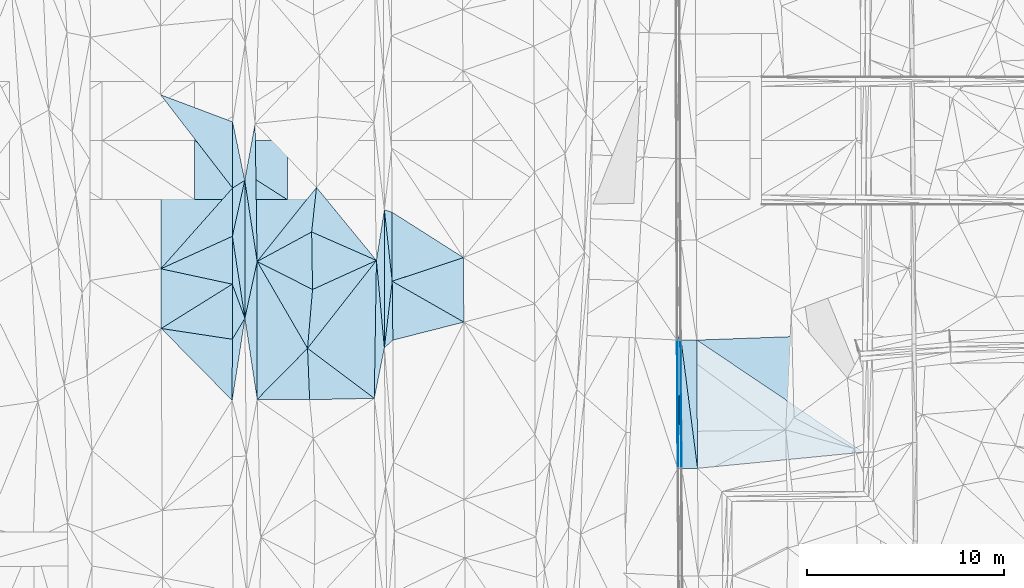
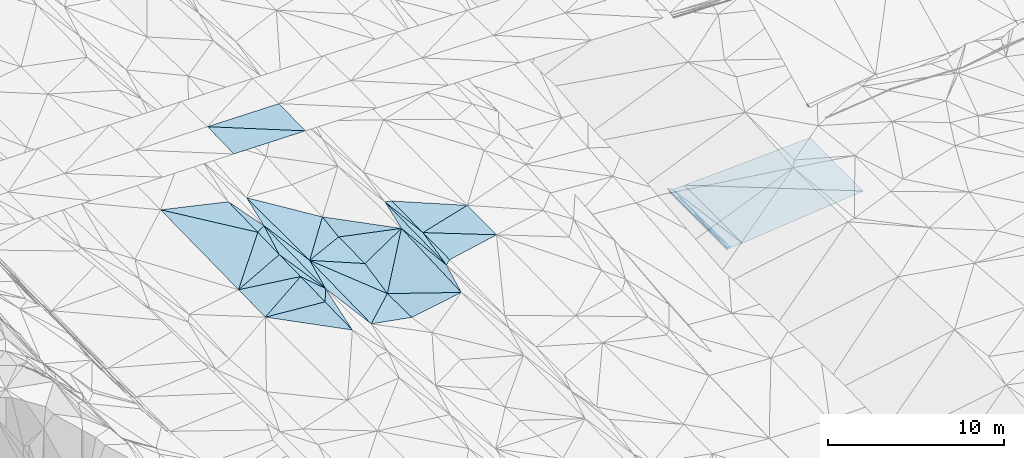
# One storey, part 94 of 275: 46 plates.
"""IFC2X3 building model written with IfcOpenShell, lengths in millimetres."""

from ifc_helpers import new_model, si_unit, frame, origin_with_axes, place, context, subcontext, project, spatial, polyline, outline, extrude, material, type_object, element, save


model = new_model("IFC2X3")

# Units and contexts
model_context = context("Model", 3, precision=1e-05, world=origin_with_axes())
body_context = subcontext(model_context, "Body", "Model", "MODEL_VIEW")
ifc_project = project(units=[si_unit("LENGTHUNIT", "METRE", prefix="MILLI"), si_unit("AREAUNIT", "SQUARE_METRE"), si_unit("VOLUMEUNIT", "CUBIC_METRE"), si_unit("MASSUNIT", "GRAM", prefix="KILO"), si_unit("TIMEUNIT", "SECOND"), si_unit("PLANEANGLEUNIT", "RADIAN"), si_unit("SOLIDANGLEUNIT", "STERADIAN"), si_unit("THERMODYNAMICTEMPERATUREUNIT", "DEGREE_CELSIUS"), si_unit("LUMINOUSINTENSITYUNIT", "LUMEN")], contexts=[model_context])

# Site, building, storey
site_placement = place(None, origin_with_axes())
site = spatial("IfcSite", under=ifc_project, at=site_placement, CompositionType="ELEMENT")
building_placement = place(site_placement, origin_with_axes())
building = spatial("IfcBuilding", under=site, at=building_placement, Name="Undefined", CompositionType="ELEMENT")
storey_placement = place(building_placement, origin_with_axes())
storey = spatial("IfcBuildingStorey", under=building, at=storey_placement, Name="Undefined", CompositionType="ELEMENT", Elevation=0.0)

# Plates
ifc_material = material()
plate_type_1 = type_object("IfcPlateType", PredefinedType="NOTDEFINED")
plate_1_placement = place(storey_placement, frame((-76301.4803001761, 52741.8011921955, 41943.5069335695), z_axis=(-0.164503150985171, 0.0230681311976254, -0.986106776489747), x_axis=(-0.698632672753425, -0.708461515449737, 0.0999733448878618)))
element("IfcPlate", 1, at=plate_1_placement, inside=storey, type_object=plate_type_1, material=ifc_material, Name="00", context=body_context, shape_type="SweptSolid", body=[
    extrude(outline(polyline([(0.0, 0.0), (3660.97583007813, 1.54977897182107e-08), (-1283.78015136719, 4962.62841796875), (0.0, 0.0)])), frame((-8.85201319254618e-08, 2.18876761149539e-07, -0.5000001331573), z_axis=(0.0, 0.0, 1.0), x_axis=(1.0, 0.0, 0.0)), (0.0, 0.0, 1.0), 1.0),
])
plate_type_2 = type_object("IfcPlateType", PredefinedType="NOTDEFINED")
plate_2_placement = place(storey_placement, frame((-57542.9530293988, 53163.1576306865, 42166.8175924955), z_axis=(0.970027688834768, 0.00927892419382977, -0.242817183205153), x_axis=(0.104742525961626, 0.885703765879376, 0.452280711906079)))
element("IfcPlate", 2, at=plate_2_placement, inside=storey, type_object=plate_type_2, material=ifc_material, Name="00_PR", context=body_context, shape_type="SweptSolid", body=[
    extrude(outline(polyline([(0.0, 0.0), (273.964813232422, 8.65838956087828e-10), (-5761.70263671875, 3058.12841796875), (0.0, 0.0)])), frame((-8.85201319254618e-08, 2.18876761149539e-07, -0.5000001331573), z_axis=(0.0, 0.0, 1.0), x_axis=(1.0, 0.0, 0.0)), (0.0, 0.0, 1.0), 1.0),
])
plate_3_placement = place(storey_placement, frame((-57475.9206408906, 46640.5409717461, 42185.3517366158), z_axis=(0.970098716719788, 0.00928046165619279, -0.242533199480129), x_axis=(-0.242518705977358, -0.00267351303617726, -0.970143045936584)))
element("IfcPlate", 3, at=plate_3_placement, inside=storey, type_object=plate_type_2, material=ifc_material, Name="00_PR", context=body_context, shape_type="SweptSolid", body=[
    extrude(outline(polyline([(0.0, 0.0), (123.693099975586, 3.20142135024071e-10), (16.7989311218262, 6522.9658203125), (0.0, 0.0)])), frame((-8.85201319254618e-08, 2.18876761149539e-07, -0.5000001331573), z_axis=(0.0, 0.0, 1.0), x_axis=(1.0, 0.0, 0.0)), (0.0, 0.0, 1.0), 1.0),
])
plate_type_3 = type_object("IfcPlateType", PredefinedType="NOTDEFINED")
plate_4_placement = place(storey_placement, frame((-57363.4039032815, 53156.8138091061, 42286.1950642399), z_axis=(-0.0018315013619723, 0.0155635878299148, -0.999877202628714), x_axis=(-0.0173369269780069, -0.999729095698535, -0.0155295259666189)))
element("IfcPlate", 4, at=plate_4_placement, inside=storey, type_object=plate_type_3, material=ifc_material, Name="00_PR", context=body_context, shape_type="SweptSolid", body=[
    extrude(outline(polyline([(0.0, 0.0), (6518.03564453125, -6.01721694692969e-09), (-246.37190246582, 155.63427734375), (0.0, 0.0)])), frame((-8.85201319254618e-08, 2.18876761149539e-07, -0.5000001331573), z_axis=(0.0, 0.0, 1.0), x_axis=(1.0, 0.0, 0.0)), (0.0, 0.0, 1.0), 1.0),
])
plate_5_placement = place(storey_placement, frame((-57476.4057313852, 46640.5440982335, 42184.9730634497), z_axis=(-8.17458339498182e-05, 0.0155332775498267, -0.99987934802464), x_axis=(0.0173369269796735, 0.999729095698539, 0.0155295259645527)))
element("IfcPlate", 5, at=plate_5_placement, inside=storey, type_object=plate_type_3, material=ifc_material, Name="00_PR", context=body_context, shape_type="SweptSolid", body=[
    extrude(outline(polyline([(0.0, 0.0), (6518.03564453125, -6.01721694692969e-09), (3.38969159126282, 149.96240234375), (0.0, 0.0)])), frame((-8.85201319254618e-08, 2.18876761149539e-07, -0.5000001331573), z_axis=(0.0, 0.0, 1.0), x_axis=(1.0, 0.0, 0.0)), (0.0, 0.0, 1.0), 1.0),
])
plate_type_4 = type_object("IfcPlateType", PredefinedType="NOTDEFINED")
plate_6_placement = place(storey_placement, frame((-57326.3971217367, 46641.3335447371, 42184.9731635191), z_axis=(0.0198966191931346, 0.0156436936725844, -0.999679648383902), x_axis=(-0.00567731102486509, 0.999863228802967, 0.0155335709749377)))
element("IfcPlate", 6, at=plate_6_placement, inside=storey, type_object=plate_type_4, material=ifc_material, Name="00_PR", context=body_context, shape_type="SweptSolid", body=[
    extrude(outline(polyline([(0.0, 0.0), (6516.37158203125, -1.07465893961489e-08), (0.0258967056870461, 30.0057029724121), (0.0, 0.0)])), frame((-8.85201319254618e-08, 2.18876761149539e-07, -0.5000001331573), z_axis=(0.0, 0.0, 1.0), x_axis=(1.0, 0.0, 0.0)), (0.0, 0.0, 1.0), 1.0),
])
plate_type_5 = type_object("IfcPlateType", PredefinedType="NOTDEFINED")
plate_7_placement = place(storey_placement, frame((-80125.2773440226, 55999.8433321233, 42489.500651023), z_axis=(0.0468589164748065, 0.0214401011975967, -0.998671399413963), x_axis=(0.348086938581272, -0.937454582870277, -0.00379318397038464)))
element("IfcPlate", 7, at=plate_7_placement, inside=storey, type_object=plate_type_5, material=ifc_material, Name="00", context=body_context, shape_type="SweptSolid", body=[
    extrude(outline(polyline([(0.0, 0.0), (1845.41516113281, -7.04312697052956e-09), (2624.07080078125, 973.833801269531), (0.0, 0.0)])), frame((-8.85201319254618e-08, 2.18876761149539e-07, -0.5000001331573), z_axis=(0.0, 0.0, 1.0), x_axis=(1.0, 0.0, 0.0)), (0.0, 0.0, 1.0), 1.0),
])
plate_type_6 = type_object("IfcPlateType", PredefinedType="NOTDEFINED")
plate_8_placement = place(storey_placement, frame((-48114.4722164906, 53466.44615414, 42475.5971621277), z_axis=(0.0199483858751365, 0.0157255967436064, -0.9996773316966), x_axis=(0.00717889702380228, -0.99985277310037, -0.0155851070262992)))
element("IfcPlate", 8, at=plate_8_placement, inside=storey, type_object=plate_type_6, material=ifc_material, Name="00_PR", context=body_context, shape_type="SweptSolid", body=[
    extrude(outline(polyline([(0.0, 0.0), (6000.72900390625, 1.8364517018199e-08), (247.582382202148, 8422.6015625), (0.0, 0.0)])), frame((-8.85201319254618e-08, 2.18876761149539e-07, -0.5000001331573), z_axis=(0.0, 0.0, 1.0), x_axis=(1.0, 0.0, 0.0)), (0.0, 0.0, 1.0), 1.0),
])
plate_type_7 = type_object("IfcPlateType", PredefinedType="NOTDEFINED")
plate_9_placement = place(storey_placement, frame((-56533.403672107, 53161.0745676189, 42302.7951620427), z_axis=(0.0199135154887718, 0.0156458617125591, -0.999679278024782), x_axis=(0.00567739699385721, -0.999863196060369, -0.0155356469874529)))
element("IfcPlate", 9, at=plate_9_placement, inside=storey, type_object=plate_type_7, material=ifc_material, Name="00_PR", context=body_context, shape_type="SweptSolid", body=[
    extrude(outline(polyline([(0.0, 0.0), (6515.46728515625, 2.04963725991547e-08), (-0.186443611979485, 800.160095214844), (0.0, 0.0)])), frame((-8.85201319254618e-08, 2.18876761149539e-07, -0.5000001331573), z_axis=(0.0, 0.0, 1.0), x_axis=(1.0, 0.0, 0.0)), (0.0, 0.0, 1.0), 1.0),
])
plate_10_placement = place(storey_placement, frame((-57296.3979868515, 46641.5204637476, 42185.573161535), z_axis=(0.0198966191931346, 0.0156436936725844, -0.999679648383902), x_axis=(-0.00567731102486509, 0.999863228802967, 0.0155335709749377)))
element("IfcPlate", 10, at=plate_10_placement, inside=storey, type_object=plate_type_7, material=ifc_material, Name="00_PR", context=body_context, shape_type="SweptSolid", body=[
    extrude(outline(polyline([(0.0, 0.0), (6516.337890625, -1.64873199537396e-08), (0.684065341949463, 800.160400390625), (0.0, 0.0)])), frame((-8.85201319254618e-08, 2.18876761149539e-07, -0.5000001331573), z_axis=(0.0, 0.0, 1.0), x_axis=(1.0, 0.0, 0.0)), (0.0, 0.0, 1.0), 1.0),
])
plate_type_8 = type_object("IfcPlateType", PredefinedType="NOTDEFINED")
plate_11_placement = place(storey_placement, frame((-56496.4127879231, 46646.4983941484, 42201.5731610095), z_axis=(0.0198946814764051, 0.0156457606167164, -0.999679654601251), x_axis=(-0.00567739699168185, 0.999863196060446, 0.0155356469832898)))
element("IfcPlate", 11, at=plate_11_placement, inside=storey, type_object=plate_type_8, material=ifc_material, Name="00_PR", context=body_context, shape_type="SweptSolid", body=[
    extrude(outline(polyline([(0.0, 0.0), (6515.46728515625, 2.04963725991547e-08), (774.961853027344, 8431.22265625), (0.0, 0.0)])), frame((-8.85201319254618e-08, 2.18876761149539e-07, -0.5000001331573), z_axis=(0.0, 0.0, 1.0), x_axis=(1.0, 0.0, 0.0)), (0.0, 0.0, 1.0), 1.0),
])
plate_type_9 = type_object("IfcPlateType", PredefinedType="NOTDEFINED")
plate_12_placement = place(storey_placement, frame((-72001.2179249865, 56147.3635564069, 42609.5001382948), z_axis=(-0.0142082783030577, 0.0199258904361821, -0.999700497007973), x_axis=(-0.109600104546313, 0.993746123494189, 0.021364904018242)))
element("IfcPlate", 12, at=plate_12_placement, inside=storey, type_object=plate_type_9, material=ifc_material, Name="00", context=body_context, shape_type="SweptSolid", body=[
    extrude(outline(polyline([(0.0, 0.0), (3650.84716796875, 1.33877620100975e-08), (3486.49755859375, 376.077423095703), (0.0, 0.0)])), frame((-8.85201319254618e-08, 2.18876761149539e-07, -0.5000001331573), z_axis=(0.0, 0.0, 1.0), x_axis=(1.0, 0.0, 0.0)), (0.0, 0.0, 1.0), 1.0),
])
plate_type_10 = type_object("IfcPlateType", PredefinedType="NOTDEFINED")
plate_13_placement = place(storey_placement, frame((-72399.5642037874, 52769.8800407918, 42538.5001024984), z_axis=(-0.00209296940102115, 0.0212636173443059, -0.999771712970777), x_axis=(-0.000254156600181072, 0.999773859136731, 0.0212641950534282)))
element("IfcPlate", 13, at=plate_13_placement, inside=storey, type_object=plate_type_10, material=ifc_material, Name="00", context=body_context, shape_type="SweptSolid", body=[
    extrude(outline(polyline([(0.0, 0.0), (7007.083984375, 9.05129127204418e-09), (3378.12890625, 399.211791992188), (0.0, 0.0)])), frame((-8.85201319254618e-08, 2.18876761149539e-07, -0.5000001331573), z_axis=(0.0, 0.0, 1.0), x_axis=(1.0, 0.0, 0.0)), (0.0, 0.0, 1.0), 1.0),
])
plate_type_11 = type_object("IfcPlateType", PredefinedType="NOTDEFINED")
plate_14_placement = place(storey_placement, frame((-80117.4673250895, 58430.5698216185, 42539.5003000876), z_axis=(0.0302887753520318, 0.0183102708429095, -0.999373465762091), x_axis=(0.215693778475776, 0.976155600391087, 0.0244220750952754)))
element("IfcPlate", 14, at=plate_14_placement, inside=storey, type_object=plate_type_11, material=ifc_material, Name="00", context=body_context, shape_type="SweptSolid", body=[
    extrude(outline(polyline([(0.0, 0.0), (2907.20581054688, 2.91038304567337e-11), (-3926.03540039063, 1517.80883789063), (0.0, 0.0)])), frame((-8.85201319254618e-08, 2.18876761149539e-07, -0.5000001331573), z_axis=(0.0, 0.0, 1.0), x_axis=(1.0, 0.0, 0.0)), (0.0, 0.0, 1.0), 1.0),
])
plate_type_12 = type_object("IfcPlateType", PredefinedType="NOTDEFINED")
for number, where, z_axis, x_axis, name in (
    (15, (-77330.6102856705, 60291.3344338534, 49029.1251709202), (-0.00857472301504208, 0.024991763543276, -0.999650881998417), (-0.999963199497799, 5.72359829353127e-05, 0.00857883291408346), "00_PR"),
    (16, (-82030.4385371025, 63291.6034738542, 49144.4471702601), (-0.00857472301504208, 0.024991763543276, -0.999650881998417), (0.999963199497715, -5.72359692649372e-05, -0.00857883292399956), "00_PR"),
):
    element("IfcPlate", number, at=place(storey_placement, frame(where, z_axis=z_axis, x_axis=x_axis)), inside=storey, type_object=plate_type_12, material=ifc_material, Name=name, context=body_context, shape_type="SweptSolid", body=[
        extrude(outline(polyline([(0.0, 0.0), (4700.17333984375, 2.53130565397441e-08), (4700.81640625, 3000.93725585938), (0.0, 0.0)])), frame((-8.85201319254618e-08, 2.18876761149539e-07, -0.5000001331573), z_axis=(0.0, 0.0, 1.0), x_axis=(1.0, 0.0, 0.0)), (0.0, 0.0, 1.0), 1.0),
    ])
plate_type_13 = type_object("IfcPlateType", PredefinedType="NOTDEFINED")
plate_15_placement = place(storey_placement, frame((-76301.4848263404, 52741.8057757175, 41943.5078425189), z_axis=(-0.173566145837038, 0.0322612454600606, -0.984293657939866), x_axis=(0.0399766785479113, -0.998408712848107, -0.0397731980266146)))
element("IfcPlate", 17, at=plate_15_placement, inside=storey, type_object=plate_type_13, material=ifc_material, Name="00", context=body_context, shape_type="SweptSolid", body=[
    extrude(outline(polyline([(0.0, 0.0), (2614.826171875, 3.52156348526478e-09), (2472.72875976563, 2699.69555664063), (0.0, 0.0)])), frame((-8.85201319254618e-08, 2.18876761149539e-07, -0.5000001331573), z_axis=(0.0, 0.0, 1.0), x_axis=(1.0, 0.0, 0.0)), (0.0, 0.0, 1.0), 1.0),
])
plate_type_14 = type_object("IfcPlateType", PredefinedType="NOTDEFINED")
plate_16_placement = place(storey_placement, frame((-78860.0964348655, 57151.8084225773, 42473.5024648238), z_axis=(-0.0977172482654074, 0.0181516132345168, -0.995048671336443), x_axis=(-0.151280629542686, 0.987943919920771, 0.0328782940060852)))
element("IfcPlate", 18, at=plate_16_placement, inside=storey, type_object=plate_type_14, material=ifc_material, Name="00", context=body_context, shape_type="SweptSolid", body=[
    extrude(outline(polyline([(0.0, 0.0), (4166.8828125, -1.18016032502055e-08), (6938.66748046875, 960.960571289063), (0.0, 0.0)])), frame((-8.85201319254618e-08, 2.18876761149539e-07, -0.5000001331573), z_axis=(0.0, 0.0, 1.0), x_axis=(1.0, 0.0, 0.0)), (0.0, 0.0, 1.0), 1.0),
])
plate_type_15 = type_object("IfcPlateType", PredefinedType="NOTDEFINED")
plate_17_placement = place(storey_placement, frame((-79490.4147656237, 61268.4578826335, 42610.5001299574), z_axis=(0.00296313343199887, 0.0238163730749042, -0.999711958622993), x_axis=(-0.848854461119518, -0.528410786682991, -0.0151044481711405)))
element("IfcPlate", 19, at=plate_17_placement, inside=storey, type_object=plate_type_15, material=ifc_material, Name="00", context=body_context, shape_type="SweptSolid", body=[
    extrude(outline(polyline([(0.0, 0.0), (728.262329101563, -4.71482053399086e-09), (-1049.36645507813, 2849.7255859375), (0.0, 0.0)])), frame((-8.85201319254618e-08, 2.18876761149539e-07, -0.5000001331573), z_axis=(0.0, 0.0, 1.0), x_axis=(1.0, 0.0, 0.0)), (0.0, 0.0, 1.0), 1.0),
])
plate_type_16 = type_object("IfcPlateType", PredefinedType="NOTDEFINED")
plate_18_placement = place(storey_placement, frame((-72399.4525242251, 52769.879803559, 42538.5124933599), z_axis=(0.221259027257067, 0.0207933858666983, -0.974993373291047), x_axis=(-0.0906220355690174, 0.995885130303632, 0.000673728020362977)))
element("IfcPlate", 20, at=plate_18_placement, inside=storey, type_object=plate_type_16, material=ifc_material, Name="00", context=body_context, shape_type="SweptSolid", body=[
    extrude(outline(polyline([(0.0, 0.0), (4452.8359375, 1.33150024339557e-08), (6976.9345703125, 649.316284179688), (0.0, 0.0)])), frame((-8.85201319254618e-08, 2.18876761149539e-07, -0.5000001331573), z_axis=(0.0, 0.0, 1.0), x_axis=(1.0, 0.0, 0.0)), (0.0, 0.0, 1.0), 1.0),
])
plate_type_17 = type_object("IfcPlateType", PredefinedType="NOTDEFINED")
plate_19_placement = place(storey_placement, frame((-72803.0471153788, 57204.364844627, 42541.5019862587), z_axis=(0.0821439293381421, -0.0349046704456952, -0.996009055608415), x_axis=(-0.911780879208614, 0.400862674522966, -0.0892454171588704)))
element("IfcPlate", 21, at=plate_19_placement, inside=storey, type_object=plate_type_17, material=ifc_material, Name="00", context=body_context, shape_type="SweptSolid", body=[
    extrude(outline(polyline([(0.0, 0.0), (3608.0283203125, -5.44969225302339e-09), (4295.9521484375, 2170.42431640625), (0.0, 0.0)])), frame((-8.85201319254618e-08, 2.18876761149539e-07, -0.5000001331573), z_axis=(0.0, 0.0, 1.0), x_axis=(1.0, 0.0, 0.0)), (0.0, 0.0, 1.0), 1.0),
])
plate_type_18 = type_object("IfcPlateType", PredefinedType="NOTDEFINED")
plate_20_placement = place(storey_placement, frame((-79482.9132750018, 54269.8509620968, 42482.5006235295), z_axis=(0.0451926836642338, 0.0224421925346116, -0.998726173351567), x_axis=(-0.152564066432652, -0.987865019260411, -0.0291017070832675)))
element("IfcPlate", 22, at=plate_20_placement, inside=storey, type_object=plate_type_18, material=ifc_material, Name="00", context=body_context, shape_type="SweptSolid", body=[
    extrude(outline(polyline([(0.0, 0.0), (4226.55615234375, 6.43194653093815e-09), (1154.64379882813, 470.589660644531), (0.0, 0.0)])), frame((-8.85201319254618e-08, 2.18876761149539e-07, -0.5000001331573), z_axis=(0.0, 0.0, 1.0), x_axis=(1.0, 0.0, 0.0)), (0.0, 0.0, 1.0), 1.0),
])
plate_type_19 = type_object("IfcPlateType", PredefinedType="NOTDEFINED")
plate_21_placement = place(storey_placement, frame((-79490.4149626069, 61268.4581842369, 42610.5001380788), z_axis=(0.00257311389830372, 0.0244425101377743, -0.999697925767094), x_axis=(-0.215693778482994, -0.97615560038944, -0.0244220750973573)))
element("IfcPlate", 23, at=plate_21_placement, inside=storey, type_object=plate_type_19, material=ifc_material, Name="00", context=body_context, shape_type="SweptSolid", body=[
    extrude(outline(polyline([(0.0, 0.0), (2907.20581054688, 2.91038304567337e-11), (509.253936767578, 520.601989746094), (0.0, 0.0)])), frame((-8.85201319254618e-08, 2.18876761149539e-07, -0.5000001331573), z_axis=(0.0, 0.0, 1.0), x_axis=(1.0, 0.0, 0.0)), (0.0, 0.0, 1.0), 1.0),
])
plate_type_20 = type_object("IfcPlateType", PredefinedType="NOTDEFINED")
plate_22_placement = place(storey_placement, frame((-83733.1710688452, 53748.7930117212, 42299.5004985629), z_axis=(0.0393835493199268, 0.02245533538534, -0.998971818399146), x_axis=(0.988074759596303, -0.149806101453469, 0.0355865341951255)))
element("IfcPlate", 24, at=plate_22_placement, inside=storey, type_object=plate_type_20, material=ifc_material, Name="00", context=body_context, shape_type="SweptSolid", body=[
    extrude(outline(polyline([(0.0, 0.0), (3653.06713867188, 5.86442183703184e-09), (4111.99658203125, 3073.67602539063), (0.0, 0.0)])), frame((-8.85201319254618e-08, 2.18876761149539e-07, -0.5000001331573), z_axis=(0.0, 0.0, 1.0), x_axis=(1.0, 0.0, 0.0)), (0.0, 0.0, 1.0), 1.0),
])
plate_type_21 = type_object("IfcPlateType", PredefinedType="NOTDEFINED")
plate_23_placement = place(storey_placement, frame((-72912.2020069105, 50200.1389818791, 42378.507028859), z_axis=(0.16082965544154, 0.0457154877842797, -0.985922875334172), x_axis=(-0.98658966516682, -0.0207230305283826, -0.161899316217646)))
element("IfcPlate", 25, at=plate_23_placement, inside=storey, type_object=plate_type_21, material=ifc_material, Name="00", context=body_context, shape_type="SweptSolid", body=[
    extrude(outline(polyline([(0.0, 0.0), (3329.22973632813, -3.73984221369028e-09), (3361.42138671875, 2614.6279296875), (0.0, 0.0)])), frame((-8.85201319254618e-08, 2.18876761149539e-07, -0.5000001331573), z_axis=(0.0, 0.0, 1.0), x_axis=(1.0, 0.0, 0.0)), (0.0, 0.0, 1.0), 1.0),
])
plate_type_22 = type_object("IfcPlateType", PredefinedType="NOTDEFINED")
plate_24_placement = place(storey_placement, frame((-75846.765348622, 60913.4255062092, 42160.5017527922), z_axis=(-0.0822351065074027, -0.0170386816792556, -0.996467295290894), x_axis=(-0.108086531503287, -0.993803708009879, 0.0259131559908293)))
element("IfcPlate", 26, at=plate_24_placement, inside=storey, type_object=plate_type_22, material=ifc_material, Name="00", context=body_context, shape_type="SweptSolid", body=[
    extrude(outline(polyline([(0.0, 0.0), (2276.83569335938, -3.63797880709171e-09), (4072.13696289063, 2597.2451171875), (0.0, 0.0)])), frame((-8.85201319254618e-08, 2.18876761149539e-07, -0.5000001331573), z_axis=(0.0, 0.0, 1.0), x_axis=(1.0, 0.0, 0.0)), (0.0, 0.0, 1.0), 1.0),
])
plate_type_23 = type_object("IfcPlateType", PredefinedType="NOTDEFINED")
plate_25_placement = place(storey_placement, frame((-72001.2329616473, 56147.3667058015, 42609.5006492933), z_axis=(-0.0442771995007238, 0.0262159245009625, -0.998675249972148), x_axis=(0.0109263306607629, -0.999583129698723, -0.0267241860493081)))
element("IfcPlate", 27, at=plate_25_placement, inside=storey, type_object=plate_type_23, material=ifc_material, Name="00", context=body_context, shape_type="SweptSolid", body=[
    extrude(outline(polyline([(0.0, 0.0), (2993.54296875, 9.32777766138315e-09), (3373.62109375, 435.666931152344), (0.0, 0.0)])), frame((-8.85201319254618e-08, 2.18876761149539e-07, -0.5000001331573), z_axis=(0.0, 0.0, 1.0), x_axis=(1.0, 0.0, 0.0)), (0.0, 0.0, 1.0), 1.0),
])
plate_type_24 = type_object("IfcPlateType", PredefinedType="NOTDEFINED")
plate_26_placement = place(storey_placement, frame((-78859.1362501359, 50148.1407715043, 42309.5038452204), z_axis=(-0.12176532663793, 0.0232187890181924, -0.992287303690462), x_axis=(-0.149526330604892, 0.987887935330424, 0.0414644870272021)))
element("IfcPlate", 28, at=plate_26_placement, inside=storey, type_object=plate_type_24, material=ifc_material, Name="00", context=body_context, shape_type="SweptSolid", body=[
    extrude(outline(polyline([(0.0, 0.0), (4172.2451171875, 1.23400241136551e-08), (6925.78662109375, 1054.40502929688), (0.0, 0.0)])), frame((-8.85201319254618e-08, 2.18876761149539e-07, -0.5000001331573), z_axis=(0.0, 0.0, 1.0), x_axis=(1.0, 0.0, 0.0)), (0.0, 0.0, 1.0), 1.0),
])
plate_type_25 = type_object("IfcPlateType", PredefinedType="NOTDEFINED")
plate_27_placement = place(storey_placement, frame((-68361.2168922839, 54071.9562079149, 42439.5004115438), z_axis=(-0.031630037027038, 0.0263669098484526, -0.999151803692868), x_axis=(-0.968899810101131, -0.246269773705247, 0.0241734677934168)))
element("IfcPlate", 29, at=plate_27_placement, inside=storey, type_object=plate_type_25, material=ifc_material, Name="00", context=body_context, shape_type="SweptSolid", body=[
    extrude(outline(polyline([(0.0, 0.0), (3723.09008789063, -1.78843038156629e-08), (3019.80346679688, 2909.75732421875), (0.0, 0.0)])), frame((-8.85201319254618e-08, 2.18876761149539e-07, -0.5000001331573), z_axis=(0.0, 0.0, 1.0), x_axis=(1.0, 0.0, 0.0)), (0.0, 0.0, 1.0), 1.0),
])
plate_type_26 = type_object("IfcPlateType", PredefinedType="NOTDEFINED")
plate_28_placement = place(storey_placement, frame((-80108.5871091585, 60883.6364535585, 42599.5004535415), z_axis=(0.035709522088674, 0.0243071481713685, -0.999066560635463), x_axis=(-0.0036178404101984, -0.999694465217053, -0.0244517370580705)))
element("IfcPlate", 30, at=plate_28_placement, inside=storey, type_object=plate_type_26, material=ifc_material, Name="00", context=body_context, shape_type="SweptSolid", body=[
    extrude(outline(polyline([(0.0, 0.0), (2453.8134765625, -3.27418092638254e-09), (4120.525390625, 3629.41748046875), (0.0, 0.0)])), frame((-8.85201319254618e-08, 2.18876761149539e-07, -0.5000001331573), z_axis=(0.0, 0.0, 1.0), x_axis=(1.0, 0.0, 0.0)), (0.0, 0.0, 1.0), 1.0),
])
plate_type_27 = type_object("IfcPlateType", PredefinedType="NOTDEFINED")
plate_29_placement = place(storey_placement, frame((-83765.7100080583, 65619.2924399021, 42569.5005075596), z_axis=(0.038976300930125, 0.0237712490959301, -0.998957344275632), x_axis=(0.935493029716941, -0.352224556268148, 0.0281185581551497)))
element("IfcPlate", 31, at=plate_29_placement, inside=storey, type_object=plate_type_27, material=ifc_material, Name="00", context=body_context, shape_type="SweptSolid", body=[
    extrude(outline(polyline([(0.0, 0.0), (3912.00708007813, -1.26310624182224e-08), (5090.072265625, 3145.32373046875), (0.0, 0.0)])), frame((-8.85201319254618e-08, 2.18876761149539e-07, -0.5000001331573), z_axis=(0.0, 0.0, 1.0), x_axis=(1.0, 0.0, 0.0)), (0.0, 0.0, 1.0), 1.0),
])
plate_type_28 = type_object("IfcPlateType", PredefinedType="NOTDEFINED")
plate_30_placement = place(storey_placement, frame((-79482.9849085467, 54269.848789531, 42482.5024822067), z_axis=(-0.0980902869053158, 0.0180933044930936, -0.995013029033968), x_axis=(-0.00106865854351368, 0.999832220763073, 0.0182862870178439)))
element("IfcPlate", 32, at=plate_30_placement, inside=storey, type_object=plate_type_28, material=ifc_material, Name="00", context=body_context, shape_type="SweptSolid", body=[
    extrude(outline(polyline([(0.0, 0.0), (6999.78076171875, -2.4156179279089e-08), (2880.64575195313, 629.000427246094), (0.0, 0.0)])), frame((-8.85201319254618e-08, 2.18876761149539e-07, -0.5000001331573), z_axis=(0.0, 0.0, 1.0), x_axis=(1.0, 0.0, 0.0)), (0.0, 0.0, 1.0), 1.0),
])
plate_type_29 = type_object("IfcPlateType", PredefinedType="NOTDEFINED")
plate_31_placement = place(storey_placement, frame((-78860.1009445242, 57151.8136639768, 42473.5030517681), z_axis=(-0.106736640661049, 0.0286344671128694, -0.993874920114979), x_axis=(0.876443154049233, 0.474737399636151, -0.0804474928567563)))
element("IfcPlate", 33, at=plate_31_placement, inside=storey, type_object=plate_type_29, material=ifc_material, Name="00", context=body_context, shape_type="SweptSolid", body=[
    extrude(outline(polyline([(0.0, 0.0), (3157.3388671875, -1.31840351969004e-08), (1817.142578125, 2597.59399414063), (0.0, 0.0)])), frame((-8.85201319254618e-08, 2.18876761149539e-07, -0.5000001331573), z_axis=(0.0, 0.0, 1.0), x_axis=(1.0, 0.0, 0.0)), (0.0, 0.0, 1.0), 1.0),
])
plate_type_30 = type_object("IfcPlateType", PredefinedType="NOTDEFINED")
plate_32_placement = place(storey_placement, frame((-75846.7867801077, 60913.4428602318, 42160.5039969809), z_axis=(-0.125113340935745, 0.0176826548881641, -0.991984866636584), x_axis=(-0.623888745481944, -0.778821673204042, 0.0648045878670832)))
element("IfcPlate", 34, at=plate_32_placement, inside=storey, type_object=plate_type_30, material=ifc_material, Name="00", context=body_context, shape_type="SweptSolid", body=[
    extrude(outline(polyline([(0.0, 0.0), (4829.90478515625, -1.37806637212634e-08), (-549.892822265625, 4486.2373046875), (0.0, 0.0)])), frame((-8.85201319254618e-08, 2.18876761149539e-07, -0.5000001331573), z_axis=(0.0, 0.0, 1.0), x_axis=(1.0, 0.0, 0.0)), (0.0, 0.0, 1.0), 1.0),
])
plate_type_31 = type_object("IfcPlateType", PredefinedType="NOTDEFINED")
plate_33_placement = place(storey_placement, frame((-72009.574810679, 59653.3769805051, 42679.5003815243), z_axis=(-0.0342828822080315, 0.019868398621178, -0.999214656980041), x_axis=(0.843105460274055, -0.536288900460993, -0.0395903788616925)))
element("IfcPlate", 35, at=plate_33_placement, inside=storey, type_object=plate_type_31, material=ifc_material, Name="00", context=body_context, shape_type="SweptSolid", body=[
    extrude(outline(polyline([(0.0, 0.0), (4293.97265625, 6.98491930961609e-09), (1890.04467773438, 2953.78247070313), (0.0, 0.0)])), frame((-8.85201319254618e-08, 2.18876761149539e-07, -0.5000001331573), z_axis=(0.0, 0.0, 1.0), x_axis=(1.0, 0.0, 0.0)), (0.0, 0.0, 1.0), 1.0),
])
plate_type_32 = type_object("IfcPlateType", PredefinedType="NOTDEFINED")
plate_34_placement = place(storey_placement, frame((-72001.2281583988, 56147.3641155162, 42609.5003983688), z_axis=(-0.0346707776062249, 0.0210359271364304, -0.999177375118998), x_axis=(0.948416932910801, 0.315936452666422, -0.0262579367930249)))
element("IfcPlate", 36, at=plate_34_placement, inside=storey, type_object=plate_type_32, material=ifc_material, Name="00", context=body_context, shape_type="SweptSolid", body=[
    extrude(outline(polyline([(0.0, 0.0), (3808.37231445313, -6.31553120911121e-09), (2801.01293945313, 3120.93359375), (0.0, 0.0)])), frame((-8.85201319254618e-08, 2.18876761149539e-07, -0.5000001331573), z_axis=(0.0, 0.0, 1.0), x_axis=(1.0, 0.0, 0.0)), (0.0, 0.0, 1.0), 1.0),
])
plate_type_33 = type_object("IfcPlateType", PredefinedType="NOTDEFINED")
plate_35_placement = place(storey_placement, frame((-80117.46373566, 58430.5708889896, 42539.5004410816), z_axis=(0.0374709878018932, 0.0204307029481878, -0.999088840619388), x_axis=(-0.00321574836280328, -0.999783335866116, -0.0205655120745492)))
element("IfcPlate", 37, at=plate_35_placement, inside=storey, type_object=plate_type_33, material=ifc_material, Name="00", context=body_context, shape_type="SweptSolid", body=[
    extrude(outline(polyline([(0.0, 0.0), (2431.2548828125, 6.95581547915936e-09), (1664.73706054688, 3630.32373046875), (0.0, 0.0)])), frame((-8.85201319254618e-08, 2.18876761149539e-07, -0.5000001331573), z_axis=(0.0, 0.0, 1.0), x_axis=(1.0, 0.0, 0.0)), (0.0, 0.0, 1.0), 1.0),
])
plate_type_34 = type_object("IfcPlateType", PredefinedType="NOTDEFINED")
plate_36_placement = place(storey_placement, frame((-80125.2811585178, 55999.8433334924, 42489.5004867088), z_axis=(0.0392310445013401, 0.021442750372639, -0.999000066868762), x_axis=(0.000576472592118574, -0.999770042652855, -0.0214366390383294)))
element("IfcPlate", 38, at=plate_36_placement, inside=storey, type_object=plate_type_34, material=ifc_material, Name="00", context=body_context, shape_type="SweptSolid", body=[
    extrude(outline(polyline([(0.0, 0.0), (2798.9462890625, -5.42786438018084e-09), (2252.5263671875, 3611.9697265625), (0.0, 0.0)])), frame((-8.85201319254618e-08, 2.18876761149539e-07, -0.5000001331573), z_axis=(0.0, 0.0, 1.0), x_axis=(1.0, 0.0, 0.0)), (0.0, 0.0, 1.0), 1.0),
])
plate_type_35 = type_object("IfcPlateType", PredefinedType="NOTDEFINED")
plate_37_placement = place(storey_placement, frame((-79482.913838337, 54269.8499430886, 42482.5005765737), z_axis=(0.0440668022849759, 0.0204039613553145, -0.998820201686664), x_axis=(-0.348086938583112, 0.937454582869584, 0.00379318397276213)))
element("IfcPlate", 39, at=plate_37_placement, inside=storey, type_object=plate_type_35, material=ifc_material, Name="00", context=body_context, shape_type="SweptSolid", body=[
    extrude(outline(polyline([(0.0, 0.0), (1845.41516113281, -7.04312697052956e-09), (4121.58056640625, 854.442077636719), (0.0, 0.0)])), frame((-8.85201319254618e-08, 2.18876761149539e-07, -0.5000001331573), z_axis=(0.0, 0.0, 1.0), x_axis=(1.0, 0.0, 0.0)), (0.0, 0.0, 1.0), 1.0),
])
plate_type_36 = type_object("IfcPlateType", PredefinedType="NOTDEFINED")
plate_38_placement = place(storey_placement, frame((-72912.1787530491, 50200.1258888342, 42378.5109530125), z_axis=(0.207340261088296, 0.0195289109472884, -0.978073942894427), x_axis=(0.0155835624566415, 0.999607929640973, 0.023262407013192)))
element("IfcPlate", 40, at=plate_38_placement, inside=storey, type_object=plate_type_36, material=ifc_material, Name="00", context=body_context, shape_type="SweptSolid", body=[
    extrude(outline(polyline([(0.0, 0.0), (7007.01318359375, -1.94049789570272e-08), (2580.45776367188, 483.064025878906), (0.0, 0.0)])), frame((-8.85201319254618e-08, 2.18876761149539e-07, -0.5000001331573), z_axis=(0.0, 0.0, 1.0), x_axis=(1.0, 0.0, 0.0)), (0.0, 0.0, 1.0), 1.0),
])
plate_type_37 = type_object("IfcPlateType", PredefinedType="NOTDEFINED")
plate_39_placement = place(storey_placement, frame((-76047.7317498332, 55729.4772412564, 42130.5033523342), z_axis=(0.111280654695924, 0.0319769925759903, -0.993274427253738), x_axis=(-0.0154064055413718, 0.999417589488196, 0.0304487190190163)))
element("IfcPlate", 41, at=plate_39_placement, inside=storey, type_object=plate_type_37, material=ifc_material, Name="00", context=body_context, shape_type="SweptSolid", body=[
    extrude(outline(polyline([(0.0, 0.0), (2922.947265625, -5.99538907408714e-09), (1436.58728027344, 3287.64404296875), (0.0, 0.0)])), frame((-8.85201319254618e-08, 2.18876761149539e-07, -0.5000001331573), z_axis=(0.0, 0.0, 1.0), x_axis=(1.0, 0.0, 0.0)), (0.0, 0.0, 1.0), 1.0),
])
plate_type_38 = type_object("IfcPlateType", PredefinedType="NOTDEFINED")
plate_40_placement = place(storey_placement, frame((-76047.8304209265, 55729.4960123289, 42130.503058219), z_axis=(-0.0860608562002655, 0.0695117032320244, -0.993861988479215), x_axis=(-0.0844175224424651, -0.99448438991806, -0.0622453220248649)))
element("IfcPlate", 42, at=plate_40_placement, inside=storey, type_object=plate_type_38, material=ifc_material, Name="00", context=body_context, shape_type="SweptSolid", body=[
    extrude(outline(polyline([(0.0, 0.0), (3004.24194335938, 9.77888703346252e-09), (-1198.43908691406, 2934.83325195313), (0.0, 0.0)])), frame((-8.85201319254618e-08, 2.18876761149539e-07, -0.5000001331573), z_axis=(0.0, 0.0, 1.0), x_axis=(1.0, 0.0, 0.0)), (0.0, 0.0, 1.0), 1.0),
])
plate_type_39 = type_object("IfcPlateType", PredefinedType="NOTDEFINED")
plate_41_placement = place(storey_placement, frame((-76301.3473008912, 52741.8164264873, 41943.5032921694), z_axis=(0.10148382306919, 0.0535625607260951, -0.99339422473846), x_axis=(0.0844175224334908, 0.994484389917549, 0.0622453220452049)))
element("IfcPlate", 43, at=plate_41_placement, inside=storey, type_object=plate_type_39, material=ifc_material, Name="00", context=body_context, shape_type="SweptSolid", body=[
    extrude(outline(polyline([(0.0, 0.0), (3004.24194335938, 9.77888703346252e-09), (4770.52001953125, 3122.9228515625), (0.0, 0.0)])), frame((-8.85201319254618e-08, 2.18876761149539e-07, -0.5000001331573), z_axis=(0.0, 0.0, 1.0), x_axis=(1.0, 0.0, 0.0)), (0.0, 0.0, 1.0), 1.0),
])
plate_type_40 = type_object("IfcPlateType", PredefinedType="NOTDEFINED")
plate_42_placement = place(storey_placement, frame((-72803.0168864973, 57204.3927068023, 42541.5052072256), z_axis=(0.14261494814066, 0.0208052453250774, -0.989559557749709), x_axis=(-0.015583562491284, -0.999607929641246, -0.0232624069782795)))
element("IfcPlate", 44, at=plate_42_placement, inside=storey, type_object=plate_type_40, material=ifc_material, Name="00", context=body_context, shape_type="SweptSolid", body=[
    extrude(outline(polyline([(0.0, 0.0), (7007.01318359375, -1.94049789570272e-08), (4529.27001953125, 3463.55615234375), (0.0, 0.0)])), frame((-8.85201319254618e-08, 2.18876761149539e-07, -0.5000001331573), z_axis=(0.0, 0.0, 1.0), x_axis=(1.0, 0.0, 0.0)), (0.0, 0.0, 1.0), 1.0),
])
plate_type_41 = type_object("IfcPlateType", PredefinedType="NOTDEFINED")
plate_43_placement = place(storey_placement, frame((-83733.1717203305, 53748.793426147, 42299.500483749), z_axis=(0.0380826247436615, 0.0232836617076194, -0.999003295685314), x_axis=(-0.00573759655236801, 0.999717120360838, 0.0230815780057509)))
element("IfcPlate", 45, at=plate_43_placement, inside=storey, type_object=plate_type_41, material=ifc_material, Name="00", context=body_context, shape_type="SweptSolid", body=[
    extrude(outline(polyline([(0.0, 0.0), (3032.72143554688, -1.08120730146766e-08), (2234.09887695313, 3623.396484375), (0.0, 0.0)])), frame((-8.85201319254618e-08, 2.18876761149539e-07, -0.5000001331573), z_axis=(0.0, 0.0, 1.0), x_axis=(1.0, 0.0, 0.0)), (0.0, 0.0, 1.0), 1.0),
])
plate_type_42 = type_object("IfcPlateType", PredefinedType="NOTDEFINED")
plate_44_placement = place(storey_placement, frame((-83765.7107230147, 65619.2918975067, 42569.5004665682), z_axis=(0.0375515385008836, 0.0226704644274658, -0.999037502798999), x_axis=(0.611204737166991, -0.791456651328663, 0.00501381414189894)))
element("IfcPlate", 46, at=plate_44_placement, inside=storey, type_object=plate_type_42, material=ifc_material, Name="00", context=body_context, shape_type="SweptSolid", body=[
    extrude(outline(polyline([(0.0, 0.0), (5983.46875, -2.05182004719973e-09), (7003.646484375, 5395.427734375), (0.0, 0.0)])), frame((-8.85201319254618e-08, 2.18876761149539e-07, -0.5000001331573), z_axis=(0.0, 0.0, 1.0), x_axis=(1.0, 0.0, 0.0)), (0.0, 0.0, 1.0), 1.0),
])

save(model, "model.ifc")
